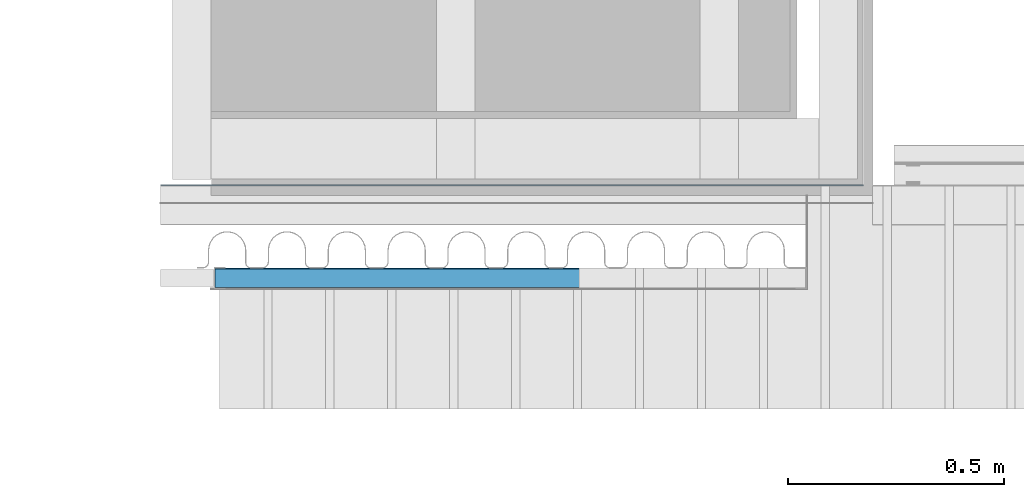
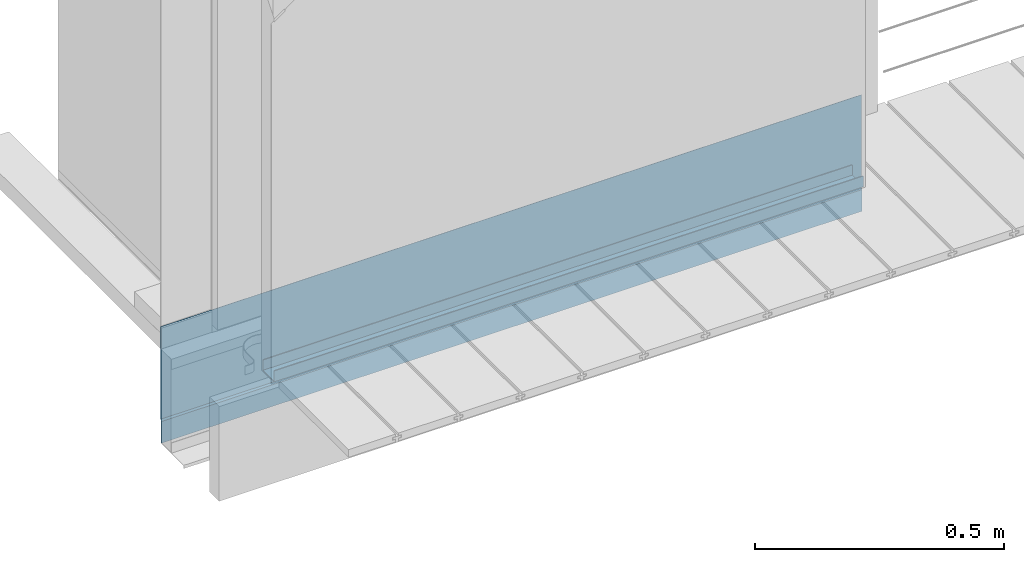
# One storey, part 11 of 33: 2 walls.
"""IFC4 building model written with IfcOpenShell, lengths in feet."""

from ifc_helpers import new_model, entity, si_unit, converted_unit, derived_unit, direction, frame, origin, place, context, subcontext, project, spatial, material, type_object, element, save


model = new_model("IFC4")

# Units and contexts
model_context = context("Model", 3, precision=0.0001, world=origin(), true_north=direction((6.12303176911189e-17, 1.0)))
body_context = subcontext(model_context, "Body", "Model", "MODEL_VIEW")
ifc_project = project(units=[converted_unit("LENGTHUNIT", "FOOT", entity("IfcRatioMeasure", 0.3048), si_unit("LENGTHUNIT", "METRE"), dimensions=[1, 0, 0, 0, 0, 0, 0]), converted_unit("AREAUNIT", "SQUARE FOOT", entity("IfcRatioMeasure", 0.09290304), si_unit("AREAUNIT", "SQUARE_METRE"), dimensions=[2, 0, 0, 0, 0, 0, 0]), converted_unit("VOLUMEUNIT", "CUBIC FOOT", entity("IfcRatioMeasure", 0.028316846592), si_unit("VOLUMEUNIT", "CUBIC_METRE"), dimensions=[3, 0, 0, 0, 0, 0, 0]), converted_unit("PLANEANGLEUNIT", "DEGREE", entity("IfcRatioMeasure", 0.0174532925199433), si_unit("PLANEANGLEUNIT", "RADIAN"), dimensions=[0, 0, 0, 0, 0, 0, 0]), si_unit("MASSUNIT", "GRAM", prefix="KILO"), derived_unit("MASSDENSITYUNIT", [(si_unit("MASSUNIT", "GRAM", prefix="KILO"), 1), (si_unit("LENGTHUNIT", "METRE"), -3)]), derived_unit("MOMENTOFINERTIAUNIT", [(si_unit("LENGTHUNIT", "METRE"), 4)]), si_unit("TIMEUNIT", "SECOND"), si_unit("FREQUENCYUNIT", "HERTZ"), si_unit("THERMODYNAMICTEMPERATUREUNIT", "DEGREE_CELSIUS"), derived_unit("THERMALTRANSMITTANCEUNIT", [(si_unit("MASSUNIT", "GRAM", prefix="KILO"), 1), (si_unit("THERMODYNAMICTEMPERATUREUNIT", "KELVIN"), -1), (si_unit("TIMEUNIT", "SECOND"), -3)]), derived_unit("VOLUMETRICFLOWRATEUNIT", [(si_unit("LENGTHUNIT", "METRE"), 3), (si_unit("TIMEUNIT", "SECOND"), -1)]), si_unit("ELECTRICCURRENTUNIT", "AMPERE"), si_unit("ELECTRICVOLTAGEUNIT", "VOLT"), si_unit("POWERUNIT", "WATT"), si_unit("FORCEUNIT", "NEWTON"), si_unit("ILLUMINANCEUNIT", "LUX"), si_unit("LUMINOUSFLUXUNIT", "LUMEN"), si_unit("LUMINOUSINTENSITYUNIT", "CANDELA"), derived_unit("USERDEFINED", [(si_unit("MASSUNIT", "GRAM", prefix="KILO"), -1), (si_unit("LENGTHUNIT", "METRE"), -2), (si_unit("TIMEUNIT", "SECOND"), 3), (si_unit("LUMINOUSFLUXUNIT", "LUMEN"), 1)]), derived_unit("LINEARVELOCITYUNIT", [(si_unit("LENGTHUNIT", "METRE"), 1), (si_unit("TIMEUNIT", "SECOND"), -1)]), si_unit("PRESSUREUNIT", "PASCAL"), derived_unit("USERDEFINED", [(si_unit("LENGTHUNIT", "METRE"), -2), (si_unit("MASSUNIT", "GRAM", prefix="KILO"), 1), (si_unit("TIMEUNIT", "SECOND"), -2)]), derived_unit("LINEARFORCEUNIT", [(si_unit("MASSUNIT", "GRAM", prefix="KILO"), 1), (si_unit("LENGTHUNIT", "METRE"), 1), (si_unit("TIMEUNIT", "SECOND"), -2), (si_unit("LENGTHUNIT", "METRE"), -1)]), derived_unit("PLANARFORCEUNIT", [(si_unit("MASSUNIT", "GRAM", prefix="KILO"), 1), (si_unit("LENGTHUNIT", "METRE"), 1), (si_unit("TIMEUNIT", "SECOND"), -2), (si_unit("LENGTHUNIT", "METRE"), -2)])], contexts=[model_context])

# Site, building, storey
site_placement = place(None, origin())
site = spatial("IfcSite", under=ifc_project, at=site_placement, CompositionType="ELEMENT")
building_placement = place(site_placement, origin())
building = spatial("IfcBuilding", under=site, at=building_placement, CompositionType="ELEMENT")
storey_placement = place(building_placement, frame((0.0, 0.0, 10.0)))
storey = spatial("IfcBuildingStorey", under=building, at=storey_placement, Name="2ND FLOOR", CompositionType="ELEMENT", Elevation=10.0000000000002)

# Walls
ifc_material_1 = material(Name="BUILDING WRAP", Category="Materials")
wall_type_1 = type_object("IfcWallType", Name="Generic Models 725:Generic Models 1", PredefinedType="NOTDEFINED", material=ifc_material_1)
wall_1_placement = place(storey_placement, frame((1486.94745796881, 4.73920581150944, -0.0735231045635594)))
cartesian_point_1 = entity("IfcCartesianPoint", [5.33128343753219, 0.0111271663702572, 0.188241360811526])
vertex_point_1 = entity("IfcVertexPoint", cartesian_point_1)
cartesian_point_2 = entity("IfcCartesianPoint", [5.33128343753219, 0.0111271663702572, 0.931520172226877])
vertex_point_2 = entity("IfcVertexPoint", cartesian_point_2)
ifc_direction_1 = entity("IfcDirection", [0.0, 0.0, 1.0])
edge_curve_1 = entity("IfcEdgeCurve", vertex_point_1, vertex_point_2, entity("IfcTrimmedCurve", entity("IfcLine", cartesian_point_1, entity("IfcVector", ifc_direction_1, 1.0)), [cartesian_point_1], [cartesian_point_2], True, "CARTESIAN"), True)
cartesian_point_3 = entity("IfcCartesianPoint", [5.33128343753219, 0.0082626072905585, 0.931520172226877])
vertex_point_3 = entity("IfcVertexPoint", cartesian_point_3)
ifc_direction_2 = entity("IfcDirection", [0.0, -1.0, 0.0])
edge_curve_2 = entity("IfcEdgeCurve", vertex_point_2, vertex_point_3, entity("IfcTrimmedCurve", entity("IfcLine", cartesian_point_2, entity("IfcVector", ifc_direction_2, 1.0)), [cartesian_point_2], [cartesian_point_3], True, "CARTESIAN"), True)
cartesian_point_4 = entity("IfcCartesianPoint", [5.33128343753219, 0.0082626072905585, 0.18848813227754])
vertex_point_4 = entity("IfcVertexPoint", cartesian_point_4)
ifc_direction_3 = entity("IfcDirection", [0.0, 0.0, -1.0])
edge_curve_3 = entity("IfcEdgeCurve", vertex_point_3, vertex_point_4, entity("IfcTrimmedCurve", entity("IfcLine", cartesian_point_3, entity("IfcVector", ifc_direction_3, 1.0)), [cartesian_point_3], [cartesian_point_4], True, "CARTESIAN"), True)
cartesian_point_5 = entity("IfcCartesianPoint", [5.33128343753219, 0.0, 0.174176876647303])
vertex_point_5 = entity("IfcVertexPoint", cartesian_point_5)
edge_curve_4 = entity("IfcEdgeCurve", vertex_point_4, vertex_point_5, entity("IfcTrimmedCurve", entity("IfcLine", cartesian_point_4, entity("IfcVector", entity("IfcDirection", [0.0, -0.500000000000002, -0.866025403784438]), 1.0)), [cartesian_point_4], [cartesian_point_5], True, "CARTESIAN"), True)
cartesian_point_6 = entity("IfcCartesianPoint", [5.33128343753219, 0.0, 0.0])
vertex_point_6 = entity("IfcVertexPoint", cartesian_point_6)
edge_curve_5 = entity("IfcEdgeCurve", vertex_point_5, vertex_point_6, entity("IfcTrimmedCurve", entity("IfcLine", cartesian_point_5, entity("IfcVector", ifc_direction_3, 1.0)), [cartesian_point_5], [cartesian_point_6], True, "CARTESIAN"), True)
cartesian_point_7 = entity("IfcCartesianPoint", [5.33128343753219, 0.00260416666666696, 0.0])
vertex_point_7 = entity("IfcVertexPoint", cartesian_point_7)
ifc_direction_4 = entity("IfcDirection", [0.0, 1.0, 0.0])
edge_curve_6 = entity("IfcEdgeCurve", vertex_point_6, vertex_point_7, entity("IfcTrimmedCurve", entity("IfcLine", cartesian_point_6, entity("IfcVector", ifc_direction_4, 1.0)), [cartesian_point_6], [cartesian_point_7], True, "CARTESIAN"), True)
cartesian_point_8 = entity("IfcCartesianPoint", [5.33128343753219, 0.00260416666666696, 0.173479092292013])
vertex_point_8 = entity("IfcVertexPoint", cartesian_point_8)
edge_curve_7 = entity("IfcEdgeCurve", vertex_point_7, vertex_point_8, entity("IfcTrimmedCurve", entity("IfcLine", cartesian_point_7, entity("IfcVector", ifc_direction_1, 1.0)), [cartesian_point_7], [cartesian_point_8], True, "CARTESIAN"), True)
edge_curve_8 = entity("IfcEdgeCurve", vertex_point_8, vertex_point_1, entity("IfcTrimmedCurve", entity("IfcLine", cartesian_point_8, entity("IfcVector", entity("IfcDirection", [0.0, 0.499999999999984, 0.866025403784448]), 1.0)), [cartesian_point_8], [cartesian_point_1], True, "CARTESIAN"), True)
ifc_direction_5 = entity("IfcDirection", [1.0, 0.0, 0.0])
cartesian_point_9 = entity("IfcCartesianPoint", [0.0, 0.0111271663703452, 0.188241360811535])
vertex_point_9 = entity("IfcVertexPoint", cartesian_point_9)
cartesian_point_10 = entity("IfcCartesianPoint", [0.0, 0.00260416666675489, 0.173479092292022])
vertex_point_10 = entity("IfcVertexPoint", cartesian_point_10)
edge_curve_9 = entity("IfcEdgeCurve", vertex_point_9, vertex_point_10, entity("IfcTrimmedCurve", entity("IfcLine", cartesian_point_9, entity("IfcVector", entity("IfcDirection", [0.0, -0.499999999999984, -0.866025403784448]), 1.0)), [cartesian_point_9], [cartesian_point_10], True, "CARTESIAN"), True)
cartesian_point_11 = entity("IfcCartesianPoint", [0.0, 0.00260416666675489, 0.0])
vertex_point_11 = entity("IfcVertexPoint", cartesian_point_11)
edge_curve_10 = entity("IfcEdgeCurve", vertex_point_10, vertex_point_11, entity("IfcTrimmedCurve", entity("IfcLine", cartesian_point_10, entity("IfcVector", ifc_direction_3, 1.0)), [cartesian_point_10], [cartesian_point_11], True, "CARTESIAN"), True)
cartesian_point_12 = entity("IfcCartesianPoint", [0.0, 0.0, 0.0])
vertex_point_12 = entity("IfcVertexPoint", cartesian_point_12)
edge_curve_11 = entity("IfcEdgeCurve", vertex_point_11, vertex_point_12, entity("IfcTrimmedCurve", entity("IfcLine", cartesian_point_11, entity("IfcVector", ifc_direction_2, 1.0)), [cartesian_point_11], [cartesian_point_12], True, "CARTESIAN"), True)
cartesian_point_13 = entity("IfcCartesianPoint", [0.0, 0.0, 0.174176876647312])
vertex_point_13 = entity("IfcVertexPoint", cartesian_point_13)
edge_curve_12 = entity("IfcEdgeCurve", vertex_point_12, vertex_point_13, entity("IfcTrimmedCurve", entity("IfcLine", cartesian_point_12, entity("IfcVector", ifc_direction_1, 1.0)), [cartesian_point_12], [cartesian_point_13], True, "CARTESIAN"), True)
cartesian_point_14 = entity("IfcCartesianPoint", [0.0, 0.00826260729064643, 0.188488132277548])
vertex_point_14 = entity("IfcVertexPoint", cartesian_point_14)
edge_curve_13 = entity("IfcEdgeCurve", vertex_point_13, vertex_point_14, entity("IfcTrimmedCurve", entity("IfcLine", cartesian_point_13, entity("IfcVector", entity("IfcDirection", [0.0, 0.500000000000002, 0.866025403784438]), 1.0)), [cartesian_point_13], [cartesian_point_14], True, "CARTESIAN"), True)
cartesian_point_15 = entity("IfcCartesianPoint", [0.0, 0.00826260729064643, 0.931520172226886])
vertex_point_15 = entity("IfcVertexPoint", cartesian_point_15)
edge_curve_14 = entity("IfcEdgeCurve", vertex_point_14, vertex_point_15, entity("IfcTrimmedCurve", entity("IfcLine", cartesian_point_14, entity("IfcVector", ifc_direction_1, 1.0)), [cartesian_point_14], [cartesian_point_15], True, "CARTESIAN"), True)
cartesian_point_16 = entity("IfcCartesianPoint", [0.0, 0.0111271663703452, 0.931520172226886])
vertex_point_16 = entity("IfcVertexPoint", cartesian_point_16)
edge_curve_15 = entity("IfcEdgeCurve", vertex_point_15, vertex_point_16, entity("IfcTrimmedCurve", entity("IfcLine", cartesian_point_15, entity("IfcVector", ifc_direction_4, 1.0)), [cartesian_point_15], [cartesian_point_16], True, "CARTESIAN"), True)
edge_curve_16 = entity("IfcEdgeCurve", vertex_point_16, vertex_point_9, entity("IfcTrimmedCurve", entity("IfcLine", cartesian_point_16, entity("IfcVector", ifc_direction_3, 1.0)), [cartesian_point_16], [cartesian_point_9], True, "CARTESIAN"), True)
ifc_direction_6 = entity("IfcDirection", [-1.0, 0.0, 0.0])
edge_curve_17 = entity("IfcEdgeCurve", vertex_point_9, vertex_point_1, entity("IfcTrimmedCurve", entity("IfcLine", cartesian_point_9, entity("IfcVector", ifc_direction_5, 1.0)), [cartesian_point_9], [cartesian_point_1], True, "CARTESIAN"), True)
edge_curve_18 = entity("IfcEdgeCurve", vertex_point_8, vertex_point_10, entity("IfcTrimmedCurve", entity("IfcLine", cartesian_point_10, entity("IfcVector", ifc_direction_6, 1.0)), [cartesian_point_8], [cartesian_point_10], True, "CARTESIAN"), True)
edge_curve_19 = entity("IfcEdgeCurve", vertex_point_7, vertex_point_11, entity("IfcTrimmedCurve", entity("IfcLine", cartesian_point_11, entity("IfcVector", ifc_direction_6, 1.0)), [cartesian_point_7], [cartesian_point_11], True, "CARTESIAN"), True)
edge_curve_20 = entity("IfcEdgeCurve", vertex_point_6, vertex_point_12, entity("IfcTrimmedCurve", entity("IfcLine", cartesian_point_12, entity("IfcVector", ifc_direction_6, 1.0)), [cartesian_point_6], [cartesian_point_12], True, "CARTESIAN"), True)
edge_curve_21 = entity("IfcEdgeCurve", vertex_point_15, vertex_point_3, entity("IfcTrimmedCurve", entity("IfcLine", cartesian_point_15, entity("IfcVector", ifc_direction_5, 1.0)), [cartesian_point_15], [cartesian_point_3], True, "CARTESIAN"), True)
edge_curve_22 = entity("IfcEdgeCurve", vertex_point_2, vertex_point_16, entity("IfcTrimmedCurve", entity("IfcLine", cartesian_point_16, entity("IfcVector", ifc_direction_6, 1.0)), [cartesian_point_2], [cartesian_point_16], True, "CARTESIAN"), True)
edge_curve_23 = entity("IfcEdgeCurve", vertex_point_5, vertex_point_13, entity("IfcTrimmedCurve", entity("IfcLine", cartesian_point_13, entity("IfcVector", ifc_direction_6, 1.0)), [cartesian_point_5], [cartesian_point_13], True, "CARTESIAN"), True)
edge_curve_24 = entity("IfcEdgeCurve", vertex_point_4, vertex_point_14, entity("IfcTrimmedCurve", entity("IfcLine", cartesian_point_14, entity("IfcVector", ifc_direction_6, 1.0)), [cartesian_point_4], [cartesian_point_14], True, "CARTESIAN"), True)
element("IfcWall", 1, at=wall_1_placement, inside=storey, type_object=wall_type_1, material=ifc_material_1, Name="Generic Models 725:Generic Models 1", ObjectType="Generic Models 725:Generic Models 1", PredefinedType="NOTDEFINED", context=body_context, shape_type="AdvancedBrep", body=[
    entity("IfcAdvancedBrep", entity("IfcClosedShell", [entity("IfcAdvancedFace", [entity("IfcFaceOuterBound", entity("IfcEdgeLoop", [entity("IfcOrientedEdge", None, None, edge_curve_1, True), entity("IfcOrientedEdge", None, None, edge_curve_2, True), entity("IfcOrientedEdge", None, None, edge_curve_3, True), entity("IfcOrientedEdge", None, None, edge_curve_4, True), entity("IfcOrientedEdge", None, None, edge_curve_5, True), entity("IfcOrientedEdge", None, None, edge_curve_6, True), entity("IfcOrientedEdge", None, None, edge_curve_7, True), entity("IfcOrientedEdge", None, None, edge_curve_8, True)]), True)], entity("IfcPlane", entity("IfcAxis2Placement3D", entity("IfcCartesianPoint", [5.33128343753219, -0.0603917087133068, 0.0643670354666153]), ifc_direction_5, entity("IfcDirection", [0.0, 0.499999999999984, 0.866025403784448]))), True), entity("IfcAdvancedFace", [entity("IfcFaceOuterBound", entity("IfcEdgeLoop", [entity("IfcOrientedEdge", None, None, edge_curve_9, True), entity("IfcOrientedEdge", None, None, edge_curve_10, True), entity("IfcOrientedEdge", None, None, edge_curve_11, True), entity("IfcOrientedEdge", None, None, edge_curve_12, True), entity("IfcOrientedEdge", None, None, edge_curve_13, True), entity("IfcOrientedEdge", None, None, edge_curve_14, True), entity("IfcOrientedEdge", None, None, edge_curve_15, True), entity("IfcOrientedEdge", None, None, edge_curve_16, True)]), True)], entity("IfcPlane", entity("IfcAxis2Placement3D", entity("IfcCartesianPoint", [0.0, -0.0603917087132189, 0.0643670354666241]), ifc_direction_6, entity("IfcDirection", [0.0, -0.499999999999984, -0.866025403784448]))), True), entity("IfcAdvancedFace", [entity("IfcFaceOuterBound", entity("IfcEdgeLoop", [entity("IfcOrientedEdge", None, None, edge_curve_9, False), entity("IfcOrientedEdge", None, None, edge_curve_17, True), entity("IfcOrientedEdge", None, None, edge_curve_8, False), entity("IfcOrientedEdge", None, None, edge_curve_18, True)]), True)], entity("IfcPlane", entity("IfcAxis2Placement3D", cartesian_point_9, entity("IfcDirection", [0.0, 0.866025403784448, -0.499999999999984]), ifc_direction_5)), True), entity("IfcAdvancedFace", [entity("IfcFaceOuterBound", entity("IfcEdgeLoop", [entity("IfcOrientedEdge", None, None, edge_curve_10, False), entity("IfcOrientedEdge", None, None, edge_curve_18, False), entity("IfcOrientedEdge", None, None, edge_curve_7, False), entity("IfcOrientedEdge", None, None, edge_curve_19, True)]), True)], entity("IfcPlane", entity("IfcAxis2Placement3D", cartesian_point_10, ifc_direction_4, ifc_direction_5)), True), entity("IfcAdvancedFace", [entity("IfcFaceOuterBound", entity("IfcEdgeLoop", [entity("IfcOrientedEdge", None, None, edge_curve_11, False), entity("IfcOrientedEdge", None, None, edge_curve_19, False), entity("IfcOrientedEdge", None, None, edge_curve_6, False), entity("IfcOrientedEdge", None, None, edge_curve_20, True)]), True)], entity("IfcPlane", entity("IfcAxis2Placement3D", cartesian_point_11, ifc_direction_3, ifc_direction_5)), True), entity("IfcAdvancedFace", [entity("IfcFaceOuterBound", entity("IfcEdgeLoop", [entity("IfcOrientedEdge", None, None, edge_curve_15, False), entity("IfcOrientedEdge", None, None, edge_curve_21, True), entity("IfcOrientedEdge", None, None, edge_curve_2, False), entity("IfcOrientedEdge", None, None, edge_curve_22, True)]), True)], entity("IfcPlane", entity("IfcAxis2Placement3D", cartesian_point_15, ifc_direction_1, ifc_direction_5)), True), entity("IfcAdvancedFace", [entity("IfcFaceOuterBound", entity("IfcEdgeLoop", [entity("IfcOrientedEdge", None, None, edge_curve_16, False), entity("IfcOrientedEdge", None, None, edge_curve_22, False), entity("IfcOrientedEdge", None, None, edge_curve_1, False), entity("IfcOrientedEdge", None, None, edge_curve_17, False)]), True)], entity("IfcPlane", entity("IfcAxis2Placement3D", cartesian_point_16, ifc_direction_4, ifc_direction_5)), True), entity("IfcAdvancedFace", [entity("IfcFaceOuterBound", entity("IfcEdgeLoop", [entity("IfcOrientedEdge", None, None, edge_curve_12, False), entity("IfcOrientedEdge", None, None, edge_curve_20, False), entity("IfcOrientedEdge", None, None, edge_curve_5, False), entity("IfcOrientedEdge", None, None, edge_curve_23, True)]), True)], entity("IfcPlane", entity("IfcAxis2Placement3D", cartesian_point_12, ifc_direction_2, ifc_direction_5)), True), entity("IfcAdvancedFace", [entity("IfcFaceOuterBound", entity("IfcEdgeLoop", [entity("IfcOrientedEdge", None, None, edge_curve_13, False), entity("IfcOrientedEdge", None, None, edge_curve_23, False), entity("IfcOrientedEdge", None, None, edge_curve_4, False), entity("IfcOrientedEdge", None, None, edge_curve_24, True)]), True)], entity("IfcPlane", entity("IfcAxis2Placement3D", cartesian_point_13, entity("IfcDirection", [0.0, -0.866025403784438, 0.500000000000002]), ifc_direction_5)), True), entity("IfcAdvancedFace", [entity("IfcFaceOuterBound", entity("IfcEdgeLoop", [entity("IfcOrientedEdge", None, None, edge_curve_14, False), entity("IfcOrientedEdge", None, None, edge_curve_24, False), entity("IfcOrientedEdge", None, None, edge_curve_3, False), entity("IfcOrientedEdge", None, None, edge_curve_21, False)]), True)], entity("IfcPlane", entity("IfcAxis2Placement3D", cartesian_point_14, ifc_direction_2, ifc_direction_5)), True)])),
])
ifc_material_2 = material(Name="GALV. METAL STUD - SILL TRACK", Category="Materials")
wall_type_2 = type_object("IfcWallType", Name="Metal stud1:Metal stud", PredefinedType="NOTDEFINED", material=ifc_material_2)
wall_2_placement = place(storey_placement, frame((1487.35885410766, 3.96511726984431, 0.745402156962701)))
cartesian_point_17 = entity("IfcCartesianPoint", [0.0, 0.151041666666732, 0.0])
vertex_point_17 = entity("IfcVertexPoint", cartesian_point_17)
cartesian_point_18 = entity("IfcCartesianPoint", [0.0, 0.0, 0.0])
vertex_point_18 = entity("IfcVertexPoint", cartesian_point_18)
ifc_direction_7 = entity("IfcDirection", [0.0, -1.0, 0.0])
edge_curve_25 = entity("IfcEdgeCurve", vertex_point_17, vertex_point_18, entity("IfcTrimmedCurve", entity("IfcLine", cartesian_point_17, entity("IfcVector", ifc_direction_7, 1.0)), [cartesian_point_17], [cartesian_point_18], True, "CARTESIAN"), True)
cartesian_point_19 = entity("IfcCartesianPoint", [0.0, 0.0, 0.0872395833333304])
vertex_point_19 = entity("IfcVertexPoint", cartesian_point_19)
ifc_direction_8 = entity("IfcDirection", [0.0, 0.0, 1.0])
edge_curve_26 = entity("IfcEdgeCurve", vertex_point_18, vertex_point_19, entity("IfcTrimmedCurve", entity("IfcLine", cartesian_point_18, entity("IfcVector", ifc_direction_8, 1.0)), [cartesian_point_18], [cartesian_point_19], True, "CARTESIAN"), True)
cartesian_point_20 = entity("IfcCartesianPoint", [0.0, 0.00520833333334769, 0.0872395833333304])
vertex_point_20 = entity("IfcVertexPoint", cartesian_point_20)
ifc_direction_9 = entity("IfcDirection", [0.0, 1.0, 0.0])
edge_curve_27 = entity("IfcEdgeCurve", vertex_point_19, vertex_point_20, entity("IfcTrimmedCurve", entity("IfcLine", cartesian_point_19, entity("IfcVector", ifc_direction_9, 1.0)), [cartesian_point_19], [cartesian_point_20], True, "CARTESIAN"), True)
cartesian_point_21 = entity("IfcCartesianPoint", [0.0, 0.00520833333333393, 0.00520833333336057])
vertex_point_21 = entity("IfcVertexPoint", cartesian_point_21)
ifc_direction_10 = entity("IfcDirection", [0.0, 0.0, -1.0])
edge_curve_28 = entity("IfcEdgeCurve", vertex_point_20, vertex_point_21, entity("IfcTrimmedCurve", entity("IfcLine", cartesian_point_20, entity("IfcVector", ifc_direction_10, 1.0)), [cartesian_point_20], [cartesian_point_21], True, "CARTESIAN"), True)
cartesian_point_22 = entity("IfcCartesianPoint", [0.0, 0.1458333333334, 0.0052083333333357])
vertex_point_22 = entity("IfcVertexPoint", cartesian_point_22)
edge_curve_29 = entity("IfcEdgeCurve", vertex_point_21, vertex_point_22, entity("IfcTrimmedCurve", entity("IfcLine", cartesian_point_21, entity("IfcVector", ifc_direction_9, 1.0)), [cartesian_point_21], [cartesian_point_22], True, "CARTESIAN"), True)
cartesian_point_23 = entity("IfcCartesianPoint", [0.0, 0.145833333333413, 0.0872395833333304])
vertex_point_23 = entity("IfcVertexPoint", cartesian_point_23)
edge_curve_30 = entity("IfcEdgeCurve", vertex_point_22, vertex_point_23, entity("IfcTrimmedCurve", entity("IfcLine", cartesian_point_22, entity("IfcVector", ifc_direction_8, 1.0)), [cartesian_point_22], [cartesian_point_23], True, "CARTESIAN"), True)
cartesian_point_24 = entity("IfcCartesianPoint", [0.0, 0.151041666666746, 0.0872395833333304])
vertex_point_24 = entity("IfcVertexPoint", cartesian_point_24)
edge_curve_31 = entity("IfcEdgeCurve", vertex_point_23, vertex_point_24, entity("IfcTrimmedCurve", entity("IfcLine", cartesian_point_23, entity("IfcVector", ifc_direction_9, 1.0)), [cartesian_point_23], [cartesian_point_24], True, "CARTESIAN"), True)
edge_curve_32 = entity("IfcEdgeCurve", vertex_point_24, vertex_point_17, entity("IfcTrimmedCurve", entity("IfcLine", cartesian_point_24, entity("IfcVector", ifc_direction_10, 1.0)), [cartesian_point_24], [cartesian_point_17], True, "CARTESIAN"), True)
ifc_direction_11 = entity("IfcDirection", [-1.0, 0.0, 0.0])
cartesian_point_25 = entity("IfcCartesianPoint", [4.48350251565967, 0.151041666666732, 0.0])
vertex_point_25 = entity("IfcVertexPoint", cartesian_point_25)
cartesian_point_26 = entity("IfcCartesianPoint", [4.48350251565967, 0.151041666666746, 0.0872395833333304])
vertex_point_26 = entity("IfcVertexPoint", cartesian_point_26)
edge_curve_33 = entity("IfcEdgeCurve", vertex_point_25, vertex_point_26, entity("IfcTrimmedCurve", entity("IfcLine", cartesian_point_25, entity("IfcVector", ifc_direction_8, 1.0)), [cartesian_point_25], [cartesian_point_26], True, "CARTESIAN"), True)
cartesian_point_27 = entity("IfcCartesianPoint", [4.48350251565967, 0.145833333333413, 0.0872395833333304])
vertex_point_27 = entity("IfcVertexPoint", cartesian_point_27)
edge_curve_34 = entity("IfcEdgeCurve", vertex_point_26, vertex_point_27, entity("IfcTrimmedCurve", entity("IfcLine", cartesian_point_26, entity("IfcVector", ifc_direction_7, 1.0)), [cartesian_point_26], [cartesian_point_27], True, "CARTESIAN"), True)
cartesian_point_28 = entity("IfcCartesianPoint", [4.48350251565967, 0.1458333333334, 0.0052083333333357])
vertex_point_28 = entity("IfcVertexPoint", cartesian_point_28)
edge_curve_35 = entity("IfcEdgeCurve", vertex_point_27, vertex_point_28, entity("IfcTrimmedCurve", entity("IfcLine", cartesian_point_27, entity("IfcVector", ifc_direction_10, 1.0)), [cartesian_point_27], [cartesian_point_28], True, "CARTESIAN"), True)
cartesian_point_29 = entity("IfcCartesianPoint", [4.48350251565967, 0.00520833333333393, 0.00520833333336057])
vertex_point_29 = entity("IfcVertexPoint", cartesian_point_29)
edge_curve_36 = entity("IfcEdgeCurve", vertex_point_28, vertex_point_29, entity("IfcTrimmedCurve", entity("IfcLine", cartesian_point_28, entity("IfcVector", ifc_direction_7, 1.0)), [cartesian_point_28], [cartesian_point_29], True, "CARTESIAN"), True)
cartesian_point_30 = entity("IfcCartesianPoint", [4.48350251565967, 0.00520833333334769, 0.0872395833333304])
vertex_point_30 = entity("IfcVertexPoint", cartesian_point_30)
edge_curve_37 = entity("IfcEdgeCurve", vertex_point_29, vertex_point_30, entity("IfcTrimmedCurve", entity("IfcLine", cartesian_point_29, entity("IfcVector", ifc_direction_8, 1.0)), [cartesian_point_29], [cartesian_point_30], True, "CARTESIAN"), True)
cartesian_point_31 = entity("IfcCartesianPoint", [4.48350251565967, 0.0, 0.0872395833333304])
vertex_point_31 = entity("IfcVertexPoint", cartesian_point_31)
edge_curve_38 = entity("IfcEdgeCurve", vertex_point_30, vertex_point_31, entity("IfcTrimmedCurve", entity("IfcLine", cartesian_point_30, entity("IfcVector", ifc_direction_7, 1.0)), [cartesian_point_30], [cartesian_point_31], True, "CARTESIAN"), True)
cartesian_point_32 = entity("IfcCartesianPoint", [4.48350251565967, 0.0, 0.0])
vertex_point_32 = entity("IfcVertexPoint", cartesian_point_32)
edge_curve_39 = entity("IfcEdgeCurve", vertex_point_31, vertex_point_32, entity("IfcTrimmedCurve", entity("IfcLine", cartesian_point_31, entity("IfcVector", ifc_direction_10, 1.0)), [cartesian_point_31], [cartesian_point_32], True, "CARTESIAN"), True)
edge_curve_40 = entity("IfcEdgeCurve", vertex_point_32, vertex_point_25, entity("IfcTrimmedCurve", entity("IfcLine", cartesian_point_32, entity("IfcVector", ifc_direction_9, 1.0)), [cartesian_point_32], [cartesian_point_25], True, "CARTESIAN"), True)
ifc_direction_12 = entity("IfcDirection", [1.0, 0.0, 0.0])
edge_curve_41 = entity("IfcEdgeCurve", vertex_point_17, vertex_point_25, entity("IfcTrimmedCurve", entity("IfcLine", cartesian_point_17, entity("IfcVector", ifc_direction_12, 1.0)), [cartesian_point_17], [cartesian_point_25], True, "CARTESIAN"), True)
edge_curve_42 = entity("IfcEdgeCurve", vertex_point_32, vertex_point_18, entity("IfcTrimmedCurve", entity("IfcLine", cartesian_point_18, entity("IfcVector", ifc_direction_11, 1.0)), [cartesian_point_32], [cartesian_point_18], True, "CARTESIAN"), True)
edge_curve_43 = entity("IfcEdgeCurve", vertex_point_31, vertex_point_19, entity("IfcTrimmedCurve", entity("IfcLine", cartesian_point_19, entity("IfcVector", ifc_direction_11, 1.0)), [cartesian_point_31], [cartesian_point_19], True, "CARTESIAN"), True)
edge_curve_44 = entity("IfcEdgeCurve", vertex_point_24, vertex_point_26, entity("IfcTrimmedCurve", entity("IfcLine", cartesian_point_24, entity("IfcVector", ifc_direction_12, 1.0)), [cartesian_point_24], [cartesian_point_26], True, "CARTESIAN"), True)
edge_curve_45 = entity("IfcEdgeCurve", vertex_point_30, vertex_point_20, entity("IfcTrimmedCurve", entity("IfcLine", cartesian_point_20, entity("IfcVector", ifc_direction_11, 1.0)), [cartesian_point_30], [cartesian_point_20], True, "CARTESIAN"), True)
edge_curve_46 = entity("IfcEdgeCurve", vertex_point_23, vertex_point_27, entity("IfcTrimmedCurve", entity("IfcLine", cartesian_point_23, entity("IfcVector", ifc_direction_12, 1.0)), [cartesian_point_23], [cartesian_point_27], True, "CARTESIAN"), True)
edge_curve_47 = entity("IfcEdgeCurve", vertex_point_29, vertex_point_21, entity("IfcTrimmedCurve", entity("IfcLine", cartesian_point_21, entity("IfcVector", ifc_direction_11, 1.0)), [cartesian_point_29], [cartesian_point_21], True, "CARTESIAN"), True)
edge_curve_48 = entity("IfcEdgeCurve", vertex_point_28, vertex_point_22, entity("IfcTrimmedCurve", entity("IfcLine", cartesian_point_22, entity("IfcVector", ifc_direction_11, 1.0)), [cartesian_point_28], [cartesian_point_22], True, "CARTESIAN"), True)
element("IfcWall", 2, at=wall_2_placement, inside=storey, type_object=wall_type_2, material=ifc_material_2, Name="Metal stud1:Metal stud", ObjectType="Metal stud1:Metal stud", PredefinedType="NOTDEFINED", context=body_context, shape_type="AdvancedBrep", body=[
    entity("IfcAdvancedBrep", entity("IfcClosedShell", [entity("IfcAdvancedFace", [entity("IfcFaceOuterBound", entity("IfcEdgeLoop", [entity("IfcOrientedEdge", None, None, edge_curve_25, True), entity("IfcOrientedEdge", None, None, edge_curve_26, True), entity("IfcOrientedEdge", None, None, edge_curve_27, True), entity("IfcOrientedEdge", None, None, edge_curve_28, True), entity("IfcOrientedEdge", None, None, edge_curve_29, True), entity("IfcOrientedEdge", None, None, edge_curve_30, True), entity("IfcOrientedEdge", None, None, edge_curve_31, True), entity("IfcOrientedEdge", None, None, edge_curve_32, True)]), True)], entity("IfcPlane", entity("IfcAxis2Placement3D", entity("IfcCartesianPoint", [0.0, 0.16666666666606, 0.0]), ifc_direction_11, ifc_direction_7)), True), entity("IfcAdvancedFace", [entity("IfcFaceOuterBound", entity("IfcEdgeLoop", [entity("IfcOrientedEdge", None, None, edge_curve_33, True), entity("IfcOrientedEdge", None, None, edge_curve_34, True), entity("IfcOrientedEdge", None, None, edge_curve_35, True), entity("IfcOrientedEdge", None, None, edge_curve_36, True), entity("IfcOrientedEdge", None, None, edge_curve_37, True), entity("IfcOrientedEdge", None, None, edge_curve_38, True), entity("IfcOrientedEdge", None, None, edge_curve_39, True), entity("IfcOrientedEdge", None, None, edge_curve_40, True)]), True)], entity("IfcPlane", entity("IfcAxis2Placement3D", entity("IfcCartesianPoint", [4.48350251565967, 0.16666666666606, 0.0]), ifc_direction_12, ifc_direction_9)), True), entity("IfcAdvancedFace", [entity("IfcFaceOuterBound", entity("IfcEdgeLoop", [entity("IfcOrientedEdge", None, None, edge_curve_25, False), entity("IfcOrientedEdge", None, None, edge_curve_41, True), entity("IfcOrientedEdge", None, None, edge_curve_40, False), entity("IfcOrientedEdge", None, None, edge_curve_42, True)]), True)], entity("IfcPlane", entity("IfcAxis2Placement3D", cartesian_point_17, ifc_direction_10, ifc_direction_12)), True), entity("IfcAdvancedFace", [entity("IfcFaceOuterBound", entity("IfcEdgeLoop", [entity("IfcOrientedEdge", None, None, edge_curve_26, False), entity("IfcOrientedEdge", None, None, edge_curve_42, False), entity("IfcOrientedEdge", None, None, edge_curve_39, False), entity("IfcOrientedEdge", None, None, edge_curve_43, True)]), True)], entity("IfcPlane", entity("IfcAxis2Placement3D", cartesian_point_18, ifc_direction_7, ifc_direction_12)), True), entity("IfcAdvancedFace", [entity("IfcFaceOuterBound", entity("IfcEdgeLoop", [entity("IfcOrientedEdge", None, None, edge_curve_32, False), entity("IfcOrientedEdge", None, None, edge_curve_44, True), entity("IfcOrientedEdge", None, None, edge_curve_33, False), entity("IfcOrientedEdge", None, None, edge_curve_41, False)]), True)], entity("IfcPlane", entity("IfcAxis2Placement3D", cartesian_point_24, ifc_direction_9, ifc_direction_12)), True), entity("IfcAdvancedFace", [entity("IfcFaceOuterBound", entity("IfcEdgeLoop", [entity("IfcOrientedEdge", None, None, edge_curve_27, False), entity("IfcOrientedEdge", None, None, edge_curve_43, False), entity("IfcOrientedEdge", None, None, edge_curve_38, False), entity("IfcOrientedEdge", None, None, edge_curve_45, True)]), True)], entity("IfcPlane", entity("IfcAxis2Placement3D", cartesian_point_19, ifc_direction_8, ifc_direction_12)), True), entity("IfcAdvancedFace", [entity("IfcFaceOuterBound", entity("IfcEdgeLoop", [entity("IfcOrientedEdge", None, None, edge_curve_31, False), entity("IfcOrientedEdge", None, None, edge_curve_46, True), entity("IfcOrientedEdge", None, None, edge_curve_34, False), entity("IfcOrientedEdge", None, None, edge_curve_44, False)]), True)], entity("IfcPlane", entity("IfcAxis2Placement3D", cartesian_point_23, ifc_direction_8, ifc_direction_12)), True), entity("IfcAdvancedFace", [entity("IfcFaceOuterBound", entity("IfcEdgeLoop", [entity("IfcOrientedEdge", None, None, edge_curve_28, False), entity("IfcOrientedEdge", None, None, edge_curve_45, False), entity("IfcOrientedEdge", None, None, edge_curve_37, False), entity("IfcOrientedEdge", None, None, edge_curve_47, True)]), True)], entity("IfcPlane", entity("IfcAxis2Placement3D", cartesian_point_20, ifc_direction_9, ifc_direction_12)), True), entity("IfcAdvancedFace", [entity("IfcFaceOuterBound", entity("IfcEdgeLoop", [entity("IfcOrientedEdge", None, None, edge_curve_29, False), entity("IfcOrientedEdge", None, None, edge_curve_47, False), entity("IfcOrientedEdge", None, None, edge_curve_36, False), entity("IfcOrientedEdge", None, None, edge_curve_48, True)]), True)], entity("IfcPlane", entity("IfcAxis2Placement3D", cartesian_point_21, ifc_direction_8, ifc_direction_12)), True), entity("IfcAdvancedFace", [entity("IfcFaceOuterBound", entity("IfcEdgeLoop", [entity("IfcOrientedEdge", None, None, edge_curve_30, False), entity("IfcOrientedEdge", None, None, edge_curve_48, False), entity("IfcOrientedEdge", None, None, edge_curve_35, False), entity("IfcOrientedEdge", None, None, edge_curve_46, False)]), True)], entity("IfcPlane", entity("IfcAxis2Placement3D", cartesian_point_22, ifc_direction_7, ifc_direction_12)), True)])),
])

save(model, "model.ifc")
